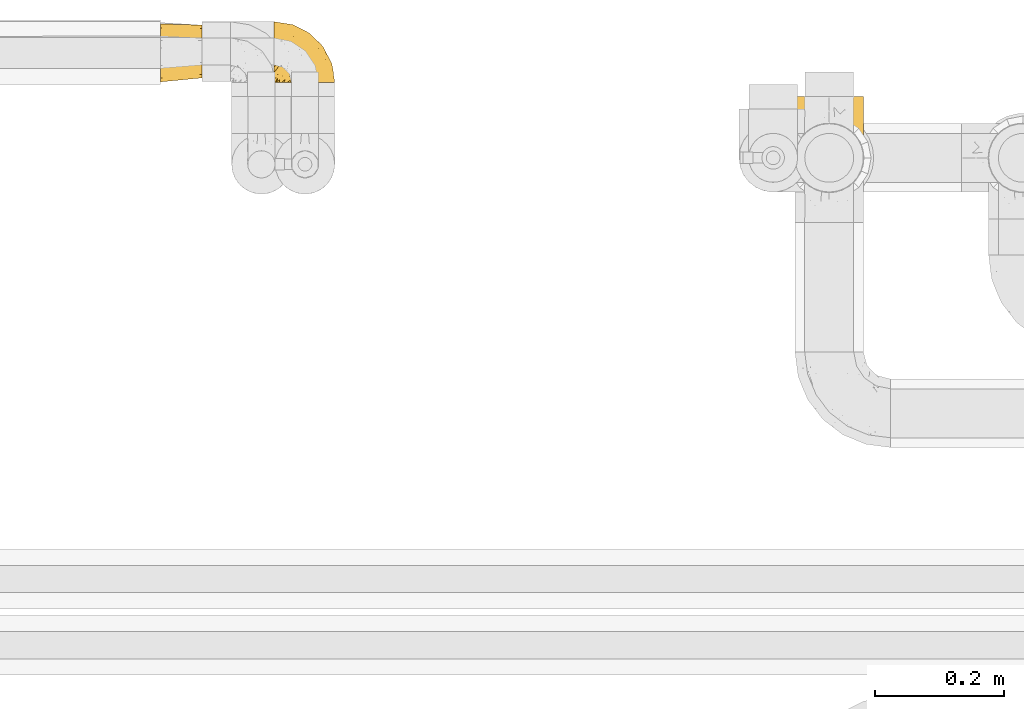
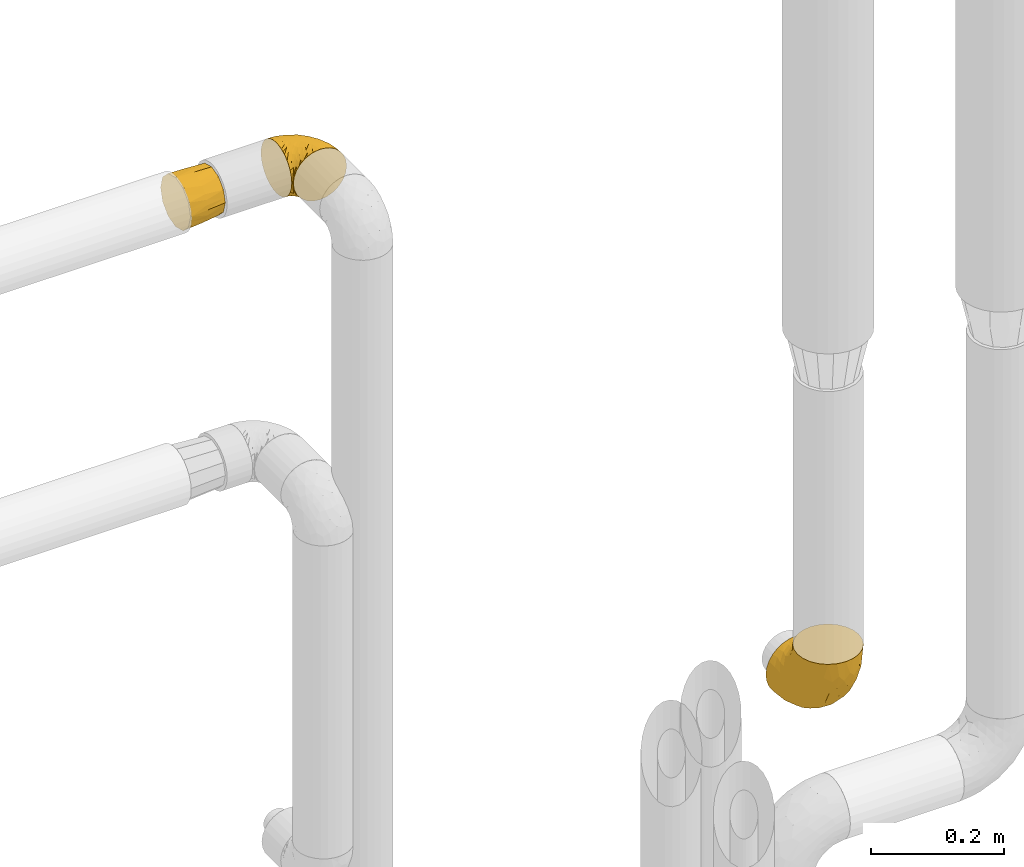
# One storey, part 319 of 827: 3 coverings.
"""IFC2X3 building model written with IfcOpenShell, lengths in millimetres."""

from ifc_helpers import new_model, entity, si_unit, converted_unit, derived_unit, direction, frame, origin, place, context, subcontext, project, spatial, faceted_brep, element, save


model = new_model("IFC2X3")

# Units and contexts
model_context = context("Model", 3, precision=0.01, world=origin(), true_north=direction((6.12303176911189e-17, 1.0)))
body_context = subcontext(model_context, "Body", "Model", "MODEL_VIEW")
ifc_project = project(units=[si_unit("LENGTHUNIT", "METRE", prefix="MILLI"), si_unit("AREAUNIT", "SQUARE_METRE"), si_unit("VOLUMEUNIT", "CUBIC_METRE"), converted_unit("PLANEANGLEUNIT", "DEGREE", entity("IfcRatioMeasure", 0.0174532925199433), si_unit("PLANEANGLEUNIT", "RADIAN"), dimensions=[0, 0, 0, 0, 0, 0, 0]), si_unit("MASSUNIT", "GRAM", prefix="KILO"), derived_unit("MASSDENSITYUNIT", [(si_unit("MASSUNIT", "GRAM", prefix="KILO"), 1), (si_unit("LENGTHUNIT", "METRE"), -3)]), derived_unit("MOMENTOFINERTIAUNIT", [(si_unit("LENGTHUNIT", "METRE"), 4)]), si_unit("TIMEUNIT", "SECOND"), si_unit("FREQUENCYUNIT", "HERTZ"), si_unit("THERMODYNAMICTEMPERATUREUNIT", "DEGREE_CELSIUS"), derived_unit("THERMALTRANSMITTANCEUNIT", [(si_unit("MASSUNIT", "GRAM", prefix="KILO"), 1), (si_unit("THERMODYNAMICTEMPERATUREUNIT", "KELVIN"), -1), (si_unit("TIMEUNIT", "SECOND"), -3)]), derived_unit("VOLUMETRICFLOWRATEUNIT", [(si_unit("LENGTHUNIT", "METRE"), 3), (si_unit("TIMEUNIT", "SECOND"), -1)]), derived_unit("MASSFLOWRATEUNIT", [(si_unit("MASSUNIT", "GRAM", prefix="KILO"), 1), (si_unit("TIMEUNIT", "SECOND"), -1)]), derived_unit("ROTATIONALFREQUENCYUNIT", [(si_unit("TIMEUNIT", "SECOND"), -1)]), si_unit("ELECTRICCURRENTUNIT", "AMPERE"), si_unit("ELECTRICVOLTAGEUNIT", "VOLT"), si_unit("POWERUNIT", "WATT"), si_unit("FORCEUNIT", "NEWTON", prefix="KILO"), si_unit("ILLUMINANCEUNIT", "LUX"), si_unit("LUMINOUSFLUXUNIT", "LUMEN"), si_unit("LUMINOUSINTENSITYUNIT", "CANDELA"), derived_unit("USERDEFINED", [(si_unit("MASSUNIT", "GRAM", prefix="KILO"), -1), (si_unit("LENGTHUNIT", "METRE"), -2), (si_unit("TIMEUNIT", "SECOND"), 3), (si_unit("LUMINOUSFLUXUNIT", "LUMEN"), 1)]), derived_unit("LINEARVELOCITYUNIT", [(si_unit("LENGTHUNIT", "METRE"), 1), (si_unit("TIMEUNIT", "SECOND"), -1)]), si_unit("PRESSUREUNIT", "PASCAL"), derived_unit("USERDEFINED", [(si_unit("LENGTHUNIT", "METRE"), -2), (si_unit("MASSUNIT", "GRAM", prefix="KILO"), 1), (si_unit("TIMEUNIT", "SECOND"), -2)]), derived_unit("LINEARFORCEUNIT", [(si_unit("MASSUNIT", "GRAM", prefix="KILO"), 1), (si_unit("LENGTHUNIT", "METRE"), 1), (si_unit("TIMEUNIT", "SECOND"), -2), (si_unit("LENGTHUNIT", "METRE"), -1)]), derived_unit("PLANARFORCEUNIT", [(si_unit("MASSUNIT", "GRAM", prefix="KILO"), 1), (si_unit("LENGTHUNIT", "METRE"), 1), (si_unit("TIMEUNIT", "SECOND"), -2), (si_unit("LENGTHUNIT", "METRE"), -2)])], contexts=[model_context])

# Site, building, storey
site_placement = place(None, origin())
site = spatial("IfcSite", under=ifc_project, at=site_placement, CompositionType="ELEMENT")
building_placement = place(site_placement, origin())
building = spatial("IfcBuilding", under=site, at=building_placement, CompositionType="ELEMENT")
storey_placement = place(building_placement, frame((0.0, 0.0, 28200.0)))
storey = spatial("IfcBuildingStorey", under=building, at=storey_placement, Name="08", CompositionType="ELEMENT", Elevation=28200.0)

# Coverings
covering_1_placement = place(storey_placement, frame((30592.61, 19468.84, 2252.2)))
element("IfcCovering", 1, at=covering_1_placement, inside=storey, Name=":ADSK_", ObjectType=":ADSK_", PredefinedType="INSULATION", context=body_context, shape_type="Brep", body=[
    faceted_brep([(1.6, 78.41, 83.91), (1.6, 85.72, 76.59), (1.6, 91.22, 67.83), (1.6, 94.64, 58.07), (1.6, 95.8, 47.8), (1.6, 94.64, 37.51), (1.6, 91.22, 27.74), (1.6, 85.71, 18.98), (1.6, 78.39, 11.67), (1.6, 69.63, 6.17), (1.6, 59.87, 2.75), (1.6, 49.6, 1.6), (1.6, 45.45, 2.06), (1.6, 42.38, 2.41), (1.6, 39.31, 2.75), (1.6, 34.43, 4.46), (1.6, 29.54, 6.17), (1.6, 25.16, 8.93), (1.6, 20.78, 11.68), (1.6, 17.13, 15.34), (1.6, 13.47, 19.0), (1.6, 7.97, 27.76), (1.6, 6.26, 32.64), (1.6, 4.55, 37.52), (1.6, 3.4, 47.8), (1.6, 4.55, 58.08), (1.6, 6.26, 62.96), (1.6, 7.97, 67.85), (1.6, 13.48, 76.61), (1.6, 17.14, 80.26), (1.6, 20.8, 83.92), (1.6, 25.18, 86.67), (1.6, 29.56, 89.42), (1.6, 34.44, 91.13), (1.6, 39.32, 92.84), (1.6, 42.39, 93.18), (1.6, 45.45, 93.53), (1.6, 49.6, 94.0), (1.6, 59.88, 92.84), (1.6, 69.65, 89.42), (3.4, 1.6, 47.8), (4.97, 1.6, 35.84), (9.58, 1.6, 24.7), (13.26, 1.6, 19.91), (16.93, 1.6, 15.13), (21.71, 1.6, 11.46), (26.5, 1.6, 7.78), (32.07, 1.6, 5.48), (37.64, 1.6, 3.17), (41.25, 1.6, 2.69), (43.34, 1.6, 2.42), (45.42, 1.6, 2.14), (49.6, 1.6, 1.6), (61.55, 1.6, 3.17), (72.7, 1.6, 7.78), (82.26, 1.6, 15.13), (89.61, 1.6, 24.7), (94.22, 1.6, 35.84), (95.8, 1.6, 47.8), (94.22, 1.6, 59.75), (89.61, 1.6, 70.9), (82.26, 1.6, 80.46), (72.7, 1.6, 87.81), (61.55, 1.6, 92.42), (49.6, 1.6, 94.0), (45.42, 1.6, 93.45), (41.25, 1.6, 92.9), (37.64, 1.6, 92.42), (32.07, 1.6, 90.11), (26.5, 1.6, 87.81), (21.71, 1.6, 84.13), (16.93, 1.6, 80.46), (13.26, 1.6, 75.68), (9.58, 1.6, 70.9), (4.97, 1.6, 59.75), (81.55, 36.81, 71.98), (90.4, 23.28, 63.6), (83.0, 45.8, 59.72), (91.18, 30.7, 47.8), (93.13, 21.2, 55.16), (94.0, 12.96, 47.8), (66.19, 66.19, 63.76), (70.92, 54.51, 72.22), (85.95, 17.98, 74.18), (49.74, 36.69, 92.52), (35.54, 35.54, 94.0), (38.14, 31.64, 94.0), (40.74, 27.75, 94.0), (43.34, 23.86, 94.0), (45.94, 19.96, 94.0), (77.59, 22.8, 82.14), (71.17, 42.67, 80.34), (65.81, 33.21, 87.52), (59.03, 59.45, 79.59), (45.85, 71.5, 78.25), (45.79, 62.66, 85.01), (41.42, 54.5, 90.25), (34.51, 47.57, 93.2), (56.04, 48.81, 87.23), (15.15, 74.98, 85.55), (56.51, 18.7, 93.0), (68.39, 15.75, 89.31), (23.33, 91.17, 61.31), (42.86, 85.28, 56.86), (39.42, 82.58, 68.34), (53.58, 75.78, 65.71), (59.17, 74.98, 56.99), (59.06, 67.27, 72.15), (22.63, 87.38, 70.34), (20.55, 82.04, 78.36), (12.96, 94.0, 47.8), (56.96, 77.8, 47.8), (67.38, 67.38, 47.8), (18.72, 56.2, 93.06), (5.33, 48.85, 94.0), (9.07, 48.11, 94.0), (11.79, 47.57, 94.0), (14.51, 47.03, 94.0), (17.24, 46.48, 94.0), (19.96, 45.94, 94.0), (21.03, 65.78, 89.88), (46.48, 17.24, 94.0), (47.03, 14.51, 94.0), (47.57, 11.79, 94.0), (48.11, 9.07, 94.0), (48.48, 7.2, 94.0), (48.85, 5.33, 94.0), (30.7, 91.18, 47.8), (23.86, 43.34, 94.0), (27.75, 40.74, 94.0), (31.64, 38.14, 94.0), (31.26, 72.73, 83.7), (77.8, 56.96, 47.8), (72.75, 62.23, 55.9), (43.83, 84.49, 47.8), (84.49, 43.83, 47.8), (14.58, 12.05, 81.75), (16.17, 18.95, 86.43), (10.82, 13.02, 79.8), (4.64, 8.34, 69.84), (7.71, 14.63, 79.5), (25.13, 11.09, 88.08), (32.66, 13.66, 91.6), (34.94, 20.08, 92.93), (36.76, 9.61, 92.43), (40.48, 9.48, 93.24), (39.25, 16.1, 93.36), (3.69, 3.42, 57.25), (13.99, 26.63, 89.41), (21.85, 33.72, 92.89), (17.93, 34.77, 92.66), (15.11, 6.75, 79.58), (21.14, 13.31, 86.51), (7.21, 19.94, 83.91), (9.47, 27.05, 88.76), (32.27, 8.67, 90.94), (25.68, 26.11, 91.94), (22.18, 29.3, 91.98), (18.79, 6.32, 82.79), (10.12, 39.92, 93.16), (10.45, 6.04, 73.94), (11.29, 34.4, 91.89), (2.87, 2.87, 47.8), (31.16, 20.92, 92.22), (12.7, 21.11, 86.29), (6.31, 27.43, 88.56), (25.62, 7.54, 87.72), (21.18, 18.45, 88.33), (28.81, 23.88, 92.18), (7.45, 7.77, 71.78), (21.14, 13.3, 9.09), (25.13, 11.09, 7.51), (18.79, 6.33, 12.8), (48.11, 9.07, 1.6), (48.85, 5.33, 1.6), (47.03, 14.51, 1.6), (47.57, 11.79, 1.6), (3.69, 3.42, 38.35), (7.44, 7.76, 23.84), (14.51, 47.03, 1.6), (11.79, 47.57, 1.6), (5.33, 48.85, 1.6), (9.07, 48.11, 1.6), (7.71, 14.62, 16.1), (9.47, 27.03, 6.84), (34.94, 20.08, 2.66), (31.16, 20.92, 3.37), (40.74, 27.75, 1.6), (38.14, 31.64, 1.6), (36.76, 9.61, 3.16), (40.48, 9.48, 2.35), (4.63, 8.33, 25.77), (15.11, 6.74, 16.02), (14.58, 12.04, 13.85), (43.34, 23.86, 1.6), (45.94, 19.96, 1.6), (39.25, 16.1, 2.23), (7.21, 19.93, 11.69), (12.69, 21.1, 9.31), (10.14, 39.92, 2.43), (21.81, 33.68, 2.71), (22.19, 29.28, 3.61), (14.0, 26.62, 6.18), (25.69, 26.08, 3.66), (16.17, 18.93, 9.17), (6.66, 27.87, 6.77), (17.92, 34.75, 2.93), (10.45, 6.04, 21.66), (31.64, 38.14, 1.6), (10.64, 12.79, 16.09), (11.31, 34.41, 3.7), (19.96, 45.94, 1.6), (23.86, 43.34, 1.6), (27.75, 40.74, 1.6), (32.66, 13.66, 3.99), (46.48, 17.24, 1.6), (32.27, 8.67, 4.65), (35.54, 35.54, 1.6), (28.77, 23.83, 3.43), (21.17, 18.43, 7.27), (23.36, 6.03, 9.46), (17.24, 46.48, 1.6), (47.58, 34.52, 2.4), (93.13, 21.2, 40.43), (77.44, 23.82, 13.57), (66.78, 41.32, 11.3), (71.68, 47.62, 18.65), (74.96, 52.66, 27.26), (81.55, 36.81, 23.61), (36.7, 49.75, 3.07), (56.9, 19.07, 2.69), (83.0, 45.8, 35.87), (90.4, 23.28, 31.99), (67.83, 21.35, 6.71), (85.95, 17.98, 21.41), (39.41, 82.57, 27.24), (23.33, 91.17, 34.26), (42.87, 85.27, 38.73), (53.92, 73.89, 26.97), (66.19, 66.19, 31.83), (64.12, 62.43, 23.4), (33.13, 63.53, 6.91), (23.1, 58.45, 3.4), (16.98, 67.16, 5.84), (72.75, 62.22, 39.69), (23.77, 81.54, 17.6), (18.41, 74.8, 10.38), (43.7, 75.83, 20.6), (54.53, 41.45, 5.36), (55.72, 76.72, 35.73), (17.73, 88.2, 24.84), (38.98, 71.6, 13.87), (50.28, 56.23, 9.06), (59.02, 59.44, 15.99)], [[[0, 1, 2, 3, 4, 5, 6, 7, 8, 9, 10, 11, 12, 13, 14, 15, 16, 17, 18, 19, 20, 21, 22, 23, 24, 25, 26, 27, 28, 29, 30, 31, 32, 33, 34, 35, 36, 37, 38, 39]], [[40, 41, 42, 43, 44, 45, 46, 47, 48, 49, 50, 51, 52, 53, 54, 55, 56, 57, 58, 59, 60, 61, 62, 63, 64, 65, 66, 67, 68, 69, 70, 71, 72, 73, 74]], [[75, 76, 77]], [[78, 79, 80]], [[77, 81, 82]], [[76, 75, 83]], [[84, 85, 86, 87, 88, 89]], [[90, 91, 92]], [[76, 60, 59]], [[93, 94, 95]], [[90, 62, 61]], [[83, 61, 60]], [[96, 97, 84]], [[98, 93, 95]], [[0, 39, 99]], [[100, 84, 89]], [[62, 101, 63]], [[2, 102, 3]], [[92, 84, 100]], [[103, 102, 104]], [[103, 105, 106]], [[93, 107, 94]], [[1, 108, 2]], [[92, 101, 90]], [[108, 1, 109]], [[102, 110, 3]], [[93, 82, 107]], [[102, 108, 104]], [[111, 106, 112]], [[109, 0, 99]], [[113, 37, 114, 115, 116, 117, 118, 119]], [[120, 38, 113]], [[100, 89, 121, 122, 123, 124, 125, 126, 64]], [[127, 102, 103]], [[97, 119, 128, 129, 130, 85]], [[99, 120, 131]], [[132, 133, 77]], [[59, 80, 79]], [[1, 0, 109]], [[98, 84, 92]], [[94, 109, 131]], [[120, 39, 38]], [[93, 91, 82]], [[104, 94, 105]], [[97, 113, 119]], [[95, 120, 96]], [[83, 90, 61]], [[91, 93, 98]], [[64, 63, 100]], [[100, 63, 101]], [[77, 76, 79]], [[133, 106, 81]], [[84, 97, 85]], [[113, 96, 120]], [[113, 97, 96]], [[37, 113, 38]], [[110, 102, 127]], [[110, 4, 3]], [[103, 111, 134, 127]], [[90, 75, 91]], [[82, 81, 107]], [[91, 75, 82]], [[77, 82, 75]], [[76, 83, 60]], [[90, 83, 75]], [[105, 107, 81]], [[94, 131, 95]], [[105, 94, 107]], [[109, 94, 104]], [[120, 95, 131]], [[98, 95, 96]], [[84, 98, 96]], [[98, 92, 91]], [[106, 105, 81]], [[103, 104, 105]], [[133, 132, 112]], [[103, 106, 111]], [[77, 78, 135, 132]], [[106, 133, 112]], [[77, 133, 81]], [[120, 99, 39]], [[109, 99, 131]], [[59, 58, 80]], [[59, 79, 76]], [[90, 101, 62]], [[100, 101, 92]], [[2, 108, 102]], [[109, 104, 108]], [[78, 77, 79]], [[136, 137, 138]], [[27, 139, 140]], [[141, 142, 143]], [[144, 145, 121]], [[146, 89, 88]], [[147, 139, 25]], [[148, 149, 150]], [[136, 151, 152]], [[147, 40, 74]], [[24, 147, 25]], [[153, 148, 154]], [[33, 116, 34]], [[73, 72, 151]], [[114, 37, 36, 35, 34, 116, 115]], [[146, 155, 144]], [[156, 85, 130]], [[157, 149, 148]], [[151, 158, 152]], [[117, 33, 159]], [[29, 153, 154]], [[160, 74, 73]], [[161, 128, 119]], [[65, 64, 126, 125, 124, 123, 122, 67, 66]], [[162, 147, 24]], [[27, 140, 28]], [[149, 129, 150]], [[139, 27, 26, 25]], [[68, 144, 69]], [[129, 128, 150]], [[163, 87, 86]], [[130, 129, 149]], [[122, 145, 67]], [[153, 164, 148]], [[161, 119, 159]], [[165, 30, 154]], [[150, 154, 148]], [[128, 161, 150]], [[30, 165, 31]], [[145, 144, 68]], [[89, 146, 144]], [[87, 163, 143]], [[166, 155, 142]], [[88, 87, 143]], [[161, 154, 150]], [[154, 30, 29]], [[29, 28, 153]], [[28, 140, 153]], [[164, 153, 140]], [[140, 137, 164]], [[157, 148, 164]], [[156, 130, 157]], [[164, 137, 157]], [[157, 137, 156]], [[167, 137, 136]], [[168, 85, 156]], [[152, 168, 167]], [[167, 168, 156]], [[163, 152, 141]], [[71, 158, 72]], [[152, 167, 136]], [[88, 142, 146]], [[144, 155, 69]], [[146, 142, 155]], [[70, 166, 71]], [[142, 141, 166]], [[70, 69, 155]], [[141, 158, 71]], [[160, 73, 151]], [[138, 137, 140]], [[160, 136, 169]], [[136, 160, 151]], [[74, 160, 169]], [[152, 158, 141]], [[151, 72, 158]], [[168, 152, 163]], [[137, 167, 156]], [[163, 86, 168]], [[85, 168, 86]], [[116, 33, 117]], [[130, 149, 157]], [[67, 145, 68]], [[121, 89, 144]], [[145, 122, 121]], [[40, 147, 162]], [[169, 147, 74]], [[159, 33, 32]], [[161, 159, 32]], [[159, 119, 118, 117]], [[139, 147, 169]], [[139, 169, 138]], [[161, 32, 31]], [[141, 143, 163]], [[88, 143, 142]], [[71, 166, 141]], [[155, 166, 70]], [[139, 138, 140]], [[169, 136, 138]], [[154, 161, 165]], [[161, 31, 165]], [[170, 171, 172]], [[173, 174, 52, 51, 50, 49, 48, 175, 176]], [[177, 178, 41]], [[179, 15, 180]], [[12, 11, 181, 182, 180, 14, 13]], [[183, 21, 20]], [[19, 18, 184]], [[185, 186, 187]], [[186, 188, 187]], [[43, 172, 44]], [[189, 190, 47]], [[23, 22, 21, 191]], [[170, 192, 193]], [[40, 162, 177]], [[194, 195, 196]], [[24, 23, 177]], [[197, 198, 183]], [[199, 15, 179]], [[47, 46, 189]], [[200, 201, 202]], [[201, 203, 204]], [[205, 206, 184]], [[207, 41, 178]], [[16, 15, 199]], [[14, 180, 15]], [[202, 201, 198]], [[208, 201, 200]], [[162, 24, 177]], [[48, 47, 190]], [[196, 195, 189]], [[197, 184, 202]], [[204, 193, 209]], [[210, 211, 212]], [[206, 212, 213]], [[205, 17, 210]], [[184, 206, 202]], [[210, 212, 206]], [[185, 194, 214]], [[189, 215, 190]], [[216, 45, 214]], [[186, 171, 170]], [[189, 216, 196]], [[197, 20, 19]], [[194, 185, 187]], [[197, 183, 20]], [[184, 197, 19]], [[197, 202, 198]], [[206, 200, 202]], [[204, 183, 198]], [[201, 208, 203]], [[203, 208, 217]], [[204, 198, 201]], [[217, 188, 218]], [[193, 219, 170]], [[171, 186, 185]], [[170, 218, 186]], [[170, 219, 218]], [[42, 207, 192]], [[171, 220, 172]], [[216, 189, 46]], [[214, 194, 196]], [[44, 220, 45]], [[214, 196, 216]], [[216, 46, 45]], [[214, 45, 220]], [[192, 43, 42]], [[204, 203, 219]], [[207, 193, 192]], [[209, 193, 178]], [[41, 207, 42]], [[193, 207, 178]], [[43, 192, 172]], [[170, 172, 192]], [[204, 219, 193]], [[219, 203, 218]], [[217, 218, 203]], [[188, 186, 218]], [[206, 213, 200]], [[208, 200, 213]], [[199, 210, 16]], [[215, 189, 195]], [[215, 175, 190]], [[175, 48, 190]], [[199, 179, 221, 211]], [[210, 199, 211]], [[23, 191, 177]], [[40, 177, 41]], [[183, 209, 191]], [[183, 191, 21]], [[191, 178, 177]], [[205, 18, 17]], [[17, 16, 210]], [[171, 185, 214]], [[172, 220, 44]], [[214, 220, 171]], [[191, 209, 178]], [[204, 209, 183]], [[206, 205, 210]], [[18, 205, 184]], [[222, 195, 194, 187, 188, 217]], [[57, 223, 80]], [[224, 225, 226]], [[226, 227, 228]], [[229, 217, 208, 213, 212, 211]], [[230, 52, 174, 173, 176, 175, 215, 195]], [[231, 232, 228]], [[231, 78, 223]], [[223, 57, 232]], [[224, 233, 225]], [[233, 54, 53]], [[234, 232, 56]], [[56, 55, 234]], [[234, 224, 228]], [[235, 236, 237]], [[224, 55, 54]], [[238, 239, 240]], [[52, 230, 53]], [[241, 242, 243]], [[231, 227, 244]], [[11, 10, 242]], [[236, 6, 5]], [[7, 245, 8]], [[8, 246, 9]], [[238, 247, 235]], [[222, 229, 248]], [[242, 211, 221, 179, 180, 182, 181, 11]], [[233, 53, 230]], [[111, 112, 249]], [[250, 6, 236]], [[246, 251, 241]], [[6, 250, 7]], [[127, 236, 110]], [[248, 229, 252]], [[246, 8, 245]], [[235, 245, 250]], [[236, 5, 110]], [[235, 249, 238]], [[237, 236, 127]], [[243, 9, 246]], [[252, 229, 241]], [[56, 232, 57]], [[222, 230, 195]], [[225, 248, 252]], [[248, 233, 230]], [[54, 233, 224]], [[231, 228, 227]], [[244, 132, 231]], [[248, 225, 233]], [[226, 225, 253]], [[235, 250, 236]], [[245, 7, 250]], [[251, 246, 245]], [[243, 246, 241]], [[247, 245, 235]], [[252, 251, 253]], [[229, 222, 217]], [[230, 222, 248]], [[5, 4, 110]], [[237, 127, 134, 111]], [[238, 249, 239]], [[224, 234, 55]], [[232, 234, 228]], [[242, 241, 229]], [[10, 9, 243]], [[211, 242, 229]], [[10, 243, 242]], [[80, 223, 78]], [[80, 58, 57]], [[231, 223, 232]], [[227, 240, 239]], [[224, 226, 228]], [[240, 226, 253]], [[227, 239, 244]], [[226, 240, 227]], [[251, 247, 253]], [[240, 253, 247]], [[249, 235, 237]], [[237, 111, 249]], [[244, 239, 249]], [[112, 244, 249]], [[135, 78, 231, 132]], [[112, 132, 244]], [[247, 238, 240]], [[245, 247, 251]], [[251, 252, 241]], [[225, 252, 253]]]),
])
covering_2_placement = place(storey_placement, frame((30418.2, 19469.61, 2253.4)))
element("IfcCovering", 2, at=covering_2_placement, inside=storey, Name=":ADSK_", ObjectType=":ADSK_", PredefinedType="INSULATION", context=body_context, shape_type="Brep", body=[
    faceted_brep([(0.0, 77.33, 77.33), (0.0, 85.57, 69.1), (0.0, 88.58, 57.85), (0.0, 91.6, 46.6), (0.0, 88.58, 35.35), (0.0, 85.57, 24.1), (0.0, 77.33, 15.86), (0.0, 69.1, 7.62), (0.0, 57.85, 4.61), (0.0, 46.6, 1.6), (0.0, 35.35, 4.61), (0.0, 24.1, 7.62), (0.0, 15.86, 15.86), (0.0, 7.62, 24.1), (0.0, 4.61, 35.35), (0.0, 1.6, 46.6), (0.0, 4.61, 57.85), (0.0, 7.62, 69.1), (0.0, 15.86, 77.33), (0.0, 24.1, 85.57), (0.0, 35.35, 88.58), (0.0, 46.6, 91.6), (0.0, 57.85, 88.58), (0.0, 69.1, 85.57), (64.0, 28.33, 82.1), (64.0, 20.82, 74.6), (64.0, 13.32, 67.1), (64.0, 9.91, 54.38), (64.0, 7.83, 46.6), (64.0, 10.57, 36.35), (64.0, 13.32, 26.1), (64.0, 20.82, 18.59), (64.0, 28.33, 11.09), (64.0, 41.04, 7.68), (64.0, 48.83, 5.6), (64.0, 59.08, 8.34), (64.0, 69.33, 11.09), (64.0, 76.83, 18.59), (64.0, 84.33, 26.1), (64.0, 87.74, 38.8), (64.0, 89.83, 46.6), (64.0, 87.08, 56.85), (64.0, 84.33, 67.1), (64.0, 76.83, 74.6), (64.0, 69.33, 82.1), (64.0, 56.62, 85.51), (64.0, 48.83, 87.6), (64.0, 38.58, 84.85), (32.0, 87.44, 30.14), (30.57, 89.92, 38.19), (31.14, 90.73, 46.6), (32.0, 83.16, 22.25), (32.0, 58.4, 4.94), (32.0, 73.89, 12.48), (32.0, 66.24, 7.79), (31.14, 47.68, 3.54), (32.0, 31.26, 6.87), (30.57, 39.25, 4.33), (32.0, 23.37, 11.15), (32.0, 6.06, 35.91), (32.0, 13.6, 20.42), (32.0, 8.91, 28.07), (31.19, 4.63, 46.6), (32.0, 7.98, 63.05), (30.57, 5.4, 55.0), (32.0, 12.26, 70.94), (32.0, 37.02, 88.25), (32.0, 21.53, 80.71), (32.0, 29.19, 85.4), (31.19, 47.68, 89.65), (32.0, 64.17, 86.32), (30.57, 56.07, 88.86), (32.0, 72.05, 82.04), (32.0, 89.36, 57.28), (32.0, 81.82, 72.77), (32.0, 86.52, 65.12)], [[[0, 1, 2, 3, 4, 5, 6, 7, 8, 9, 10, 11, 12, 13, 14, 15, 16, 17, 18, 19, 20, 21, 22, 23]], [[24, 25, 26, 27, 28, 29, 30, 31, 32, 33, 34, 35, 36, 37, 38, 39, 40, 41, 42, 43, 44, 45, 46, 47]], [[39, 48, 49]], [[39, 50, 40]], [[48, 39, 38]], [[5, 4, 48]], [[51, 5, 48]], [[48, 4, 49]], [[9, 8, 52]], [[53, 51, 37]], [[51, 48, 38]], [[7, 53, 54]], [[54, 53, 36]], [[37, 36, 53]], [[51, 38, 37]], [[50, 49, 3]], [[53, 6, 51]], [[6, 5, 51]], [[6, 53, 7]], [[52, 8, 54]], [[54, 35, 52]], [[54, 36, 35]], [[3, 49, 4]], [[8, 7, 54]], [[34, 55, 9, 52]], [[39, 49, 50]], [[34, 52, 35]], [[33, 56, 57]], [[33, 55, 34]], [[56, 33, 32]], [[11, 10, 56]], [[58, 11, 56]], [[56, 10, 57]], [[15, 14, 59]], [[60, 58, 31]], [[58, 56, 32]], [[13, 60, 61]], [[61, 60, 30]], [[31, 30, 60]], [[58, 32, 31]], [[55, 57, 9]], [[60, 12, 58]], [[12, 11, 58]], [[12, 60, 13]], [[59, 14, 61]], [[61, 29, 59]], [[61, 30, 29]], [[9, 57, 10]], [[14, 13, 61]], [[28, 62, 15, 59]], [[33, 57, 55]], [[28, 59, 29]], [[27, 63, 64]], [[27, 62, 28]], [[63, 27, 26]], [[17, 16, 63]], [[65, 17, 63]], [[63, 16, 64]], [[21, 20, 66]], [[67, 65, 25]], [[65, 63, 26]], [[19, 67, 68]], [[68, 67, 24]], [[25, 24, 67]], [[65, 26, 25]], [[62, 64, 15]], [[67, 18, 65]], [[18, 17, 65]], [[18, 67, 19]], [[66, 20, 68]], [[68, 47, 66]], [[68, 24, 47]], [[15, 64, 16]], [[20, 19, 68]], [[46, 69, 21, 66]], [[27, 64, 62]], [[46, 66, 47]], [[45, 70, 71]], [[45, 69, 46]], [[70, 45, 44]], [[23, 22, 70]], [[72, 23, 70]], [[70, 22, 71]], [[3, 2, 73]], [[74, 72, 43]], [[72, 70, 44]], [[1, 74, 75]], [[75, 74, 42]], [[43, 42, 74]], [[72, 44, 43]], [[69, 71, 21]], [[74, 0, 72]], [[0, 23, 72]], [[0, 74, 1]], [[73, 2, 75]], [[75, 41, 73]], [[75, 42, 41]], [[21, 71, 22]], [[2, 1, 75]], [[40, 50, 3, 73]], [[45, 71, 69]], [[40, 73, 41]]]),
])
covering_3_placement = place(storey_placement, frame((31400.76, 19298.79, 1075.8)))
element("IfcCovering", 3, at=covering_3_placement, inside=storey, Name=":ADSK_", ObjectType=":ADSK_", PredefinedType="INSULATION", context=body_context, shape_type="Brep", body=[
    faceted_brep([(66.44, 149.65, 2.92), (54.65, 149.65, 1.6), (42.84, 149.65, 2.93), (31.62, 149.65, 6.85), (21.56, 149.65, 13.18), (13.16, 149.65, 21.58), (6.84, 149.65, 31.64), (2.92, 149.65, 42.85), (1.6, 149.65, 54.65), (2.93, 149.65, 66.46), (6.85, 149.65, 77.67), (13.18, 149.65, 87.73), (21.58, 149.65, 96.13), (31.64, 149.65, 102.45), (42.85, 149.65, 106.37), (54.65, 149.65, 107.7), (66.46, 149.65, 106.36), (77.67, 149.65, 102.44), (87.73, 149.65, 96.11), (96.13, 149.65, 87.71), (102.45, 149.65, 77.65), (106.37, 149.65, 66.44), (107.7, 149.65, 54.65), (106.36, 149.65, 42.84), (102.44, 149.65, 31.62), (96.11, 149.65, 21.56), (87.71, 149.65, 13.16), (77.65, 149.65, 6.84), (40.91, 105.89, 149.65), (28.12, 100.59, 149.65), (17.13, 92.16, 149.65), (8.7, 81.17, 149.65), (3.4, 68.38, 149.65), (1.6, 54.65, 149.65), (3.4, 40.91, 149.65), (8.7, 28.12, 149.65), (17.13, 17.13, 149.65), (28.12, 8.7, 149.65), (40.91, 3.4, 149.65), (54.65, 1.6, 149.65), (68.38, 3.4, 149.65), (81.17, 8.7, 149.65), (92.16, 17.13, 149.65), (100.59, 28.12, 149.65), (105.89, 40.91, 149.65), (107.7, 54.65, 149.65), (105.89, 68.38, 149.65), (100.59, 81.17, 149.65), (92.16, 92.16, 149.65), (81.17, 100.59, 149.65), (68.38, 105.89, 149.65), (54.65, 107.7, 149.65), (85.53, 14.05, 123.27), (73.42, 9.45, 114.15), (83.77, 22.36, 92.97), (64.22, 4.7, 124.11), (54.65, 6.64, 111.33), (96.72, 81.47, 42.13), (93.36, 56.83, 56.83), (84.47, 64.02, 40.31), (71.37, 34.04, 61.55), (54.65, 21.43, 75.62), (54.65, 44.96, 44.96), (103.47, 49.8, 91.12), (100.91, 35.43, 109.83), (99.1, 42.1, 88.02), (105.43, 43.59, 119.19), (106.79, 57.88, 99.11), (89.81, 91.8, 27.97), (79.59, 88.01, 21.92), (81.29, 115.65, 12.94), (74.01, 18.94, 88.29), (64.14, 12.83, 95.35), (94.75, 24.96, 113.84), (54.65, 111.33, 6.64), (70.74, 113.8, 8.58), (68.3, 60.89, 33.39), (66.05, 86.24, 17.23), (100.73, 65.84, 61.99), (106.78, 124.58, 47.9), (103.6, 121.36, 37.72), (107.7, 72.79, 93.81), (107.7, 66.04, 107.05), (107.7, 59.29, 120.29), (106.07, 73.26, 73.26), (90.59, 121.69, 18.58), (97.43, 109.82, 29.72), (84.51, 40.11, 64.31), (93.3, 36.57, 82.84), (107.7, 93.81, 72.79), (107.7, 83.3, 83.3), (107.7, 136.6, 56.71), (107.7, 120.29, 59.29), (106.79, 99.11, 57.88), (107.7, 107.05, 66.04), (103.47, 91.12, 49.8), (54.65, 75.62, 21.43), (107.7, 56.97, 134.97), (76.99, 126.65, 108.79), (84.28, 116.55, 110.84), (91.11, 120.09, 101.53), (106.26, 76.06, 111.84), (102.6, 83.69, 119.98), (106.08, 71.88, 123.54), (106.56, 66.92, 134.54), (105.36, 110.43, 80.57), (106.74, 121.31, 69.55), (101.59, 81.0, 134.56), (54.65, 113.32, 128.67), (54.65, 111.09, 136.98), (67.71, 109.14, 133.56), (91.36, 95.86, 131.66), (94.33, 99.07, 117.75), (87.1, 106.92, 118.23), (65.84, 131.39, 110.55), (54.65, 136.98, 111.09), (54.65, 128.67, 113.32), (68.92, 117.07, 120.2), (100.82, 96.39, 105.95), (79.83, 106.61, 127.69), (77.13, 103.72, 139.88), (105.9, 92.14, 92.14), (101.53, 107.13, 93.82), (106.72, 98.03, 82.28), (97.75, 88.38, 130.86), (103.08, 130.66, 78.78), (106.39, 135.45, 67.58), (98.1, 123.57, 90.58), (95.02, 137.75, 90.23), (86.9, 133.2, 99.39), (74.42, 138.8, 105.17), (54.65, 120.99, 120.99), (105.28, 84.53, 104.59), (92.87, 108.72, 108.24), (17.93, 95.86, 131.66), (6.22, 130.67, 78.8), (41.58, 109.13, 133.57), (1.6, 93.81, 72.79), (2.57, 98.02, 82.27), (3.94, 110.43, 80.59), (43.46, 131.4, 110.55), (32.32, 126.66, 108.79), (40.38, 117.08, 120.2), (16.44, 108.74, 108.25), (8.47, 96.31, 106.06), (15.01, 99.11, 117.78), (11.21, 123.58, 90.6), (7.78, 107.12, 93.87), (1.6, 72.79, 93.81), (1.6, 66.04, 107.05), (3.04, 76.07, 111.89), (1.6, 56.97, 134.97), (2.73, 66.92, 134.54), (1.6, 120.29, 59.29), (1.6, 107.05, 66.04), (2.55, 121.26, 69.56), (3.98, 84.46, 104.56), (6.69, 83.69, 119.98), (7.7, 81.0, 134.56), (3.21, 71.88, 123.54), (14.28, 137.76, 90.25), (22.42, 133.21, 99.4), (25.02, 116.58, 110.83), (18.18, 120.1, 101.52), (34.89, 138.81, 105.18), (1.6, 136.6, 56.71), (32.17, 103.72, 139.89), (22.23, 106.96, 118.22), (2.91, 135.44, 67.6), (11.54, 88.38, 130.86), (1.6, 83.3, 83.3), (3.38, 92.12, 92.12), (29.46, 106.6, 127.71), (1.6, 59.29, 120.29), (25.52, 22.36, 92.97), (23.76, 14.05, 123.27), (14.54, 24.96, 113.84), (8.38, 35.43, 109.83), (45.07, 4.71, 124.03), (35.87, 9.45, 114.15), (45.14, 11.79, 98.04), (2.5, 57.88, 99.11), (2.51, 124.57, 47.9), (5.68, 121.37, 37.74), (5.82, 91.12, 49.8), (15.93, 56.83, 56.83), (12.54, 81.48, 42.16), (24.81, 64.05, 40.3), (2.5, 99.11, 57.88), (3.22, 73.26, 73.26), (3.86, 43.59, 119.19), (35.85, 19.5, 86.61), (19.47, 91.8, 27.99), (18.68, 121.7, 18.59), (29.68, 88.04, 21.92), (27.95, 123.34, 11.28), (40.99, 60.89, 33.39), (37.92, 34.04, 61.55), (11.85, 109.85, 29.73), (10.19, 42.1, 88.01), (8.55, 65.78, 62.08), (38.53, 113.81, 8.58), (15.99, 36.57, 82.84), (24.79, 40.12, 64.3), (5.82, 49.8, 91.12), (40.56, 86.08, 18.05)], [[[0, 1, 2, 3, 4, 5, 6, 7, 8, 9, 10, 11, 12, 13, 14, 15, 16, 17, 18, 19, 20, 21, 22, 23, 24, 25, 26, 27]], [[28, 29, 30, 31, 32, 33, 34, 35, 36, 37, 38, 39, 40, 41, 42, 43, 44, 45, 46, 47, 48, 49, 50, 51]], [[52, 53, 54]], [[55, 39, 56]], [[57, 58, 59]], [[60, 61, 62]], [[63, 64, 65]], [[66, 63, 67]], [[68, 69, 70]], [[53, 71, 54]], [[41, 40, 53]], [[53, 72, 71]], [[73, 42, 52]], [[42, 41, 52]], [[74, 0, 75]], [[69, 76, 77]], [[43, 73, 64]], [[45, 44, 66]], [[57, 78, 58]], [[23, 79, 80]], [[67, 81, 82, 83]], [[67, 84, 81]], [[24, 23, 80]], [[25, 85, 26]], [[86, 85, 25]], [[42, 73, 43]], [[0, 27, 75]], [[25, 24, 86]], [[70, 26, 85]], [[0, 74, 1]], [[68, 85, 86]], [[66, 64, 63]], [[60, 59, 87]], [[54, 87, 88]], [[76, 60, 62]], [[84, 89, 90, 81]], [[79, 22, 91, 92]], [[77, 74, 75]], [[93, 92, 94, 89]], [[80, 86, 24]], [[40, 55, 53]], [[76, 59, 60]], [[93, 84, 95]], [[76, 62, 96]], [[55, 72, 53]], [[70, 27, 26]], [[75, 70, 69]], [[78, 84, 63]], [[93, 79, 92]], [[95, 86, 80]], [[77, 76, 96]], [[59, 69, 68]], [[57, 68, 86]], [[68, 57, 59]], [[59, 58, 87]], [[76, 69, 59]], [[88, 87, 58]], [[87, 54, 71]], [[86, 95, 57]], [[78, 57, 95]], [[84, 78, 95]], [[78, 63, 65]], [[58, 78, 65]], [[54, 88, 73]], [[84, 93, 89]], [[79, 95, 80]], [[79, 93, 95]], [[22, 79, 23]], [[66, 83, 97, 45]], [[84, 67, 63]], [[83, 66, 67]], [[64, 44, 43]], [[64, 66, 44]], [[65, 73, 88]], [[53, 52, 41]], [[73, 52, 54]], [[73, 65, 64]], [[65, 88, 58]], [[39, 55, 40]], [[72, 55, 56]], [[56, 61, 72]], [[60, 72, 61]], [[72, 60, 71]], [[87, 71, 60]], [[27, 70, 75]], [[68, 70, 85]], [[74, 77, 96]], [[69, 77, 75]], [[98, 99, 100]], [[46, 45, 97]], [[101, 102, 103]], [[103, 104, 83]], [[105, 94, 106]], [[107, 103, 102]], [[108, 109, 51, 110]], [[111, 112, 113]], [[114, 115, 116]], [[47, 104, 107]], [[110, 117, 108]], [[49, 48, 111]], [[102, 118, 112]], [[119, 120, 111]], [[50, 49, 120]], [[121, 122, 118]], [[105, 123, 89]], [[124, 48, 107]], [[20, 19, 125]], [[121, 81, 90]], [[117, 119, 99]], [[21, 20, 126]], [[22, 21, 91]], [[105, 125, 127]], [[110, 51, 50]], [[19, 128, 125]], [[16, 15, 115]], [[129, 98, 100]], [[126, 91, 21]], [[128, 129, 127]], [[122, 123, 105]], [[114, 117, 98]], [[17, 16, 130]], [[18, 128, 19]], [[129, 18, 17]], [[125, 106, 126]], [[115, 114, 16]], [[130, 129, 17]], [[114, 98, 130]], [[117, 116, 131, 108]], [[99, 119, 113]], [[122, 121, 123]], [[92, 126, 106]], [[105, 127, 122]], [[132, 121, 118]], [[114, 130, 16]], [[129, 130, 98]], [[50, 120, 110]], [[129, 128, 18]], [[125, 128, 127]], [[125, 126, 20]], [[91, 126, 92]], [[105, 89, 94]], [[105, 106, 125]], [[94, 92, 106]], [[100, 122, 127]], [[118, 122, 133]], [[112, 118, 133]], [[132, 118, 102]], [[132, 102, 101]], [[81, 121, 132]], [[82, 103, 83]], [[132, 101, 81]], [[104, 47, 46]], [[124, 107, 102]], [[48, 47, 107]], [[113, 112, 133]], [[112, 111, 124]], [[99, 113, 133]], [[111, 113, 119]], [[99, 133, 100]], [[117, 99, 98]], [[122, 100, 133]], [[127, 129, 100]], [[103, 82, 101]], [[81, 101, 82]], [[112, 124, 102]], [[48, 124, 111]], [[104, 103, 107]], [[46, 97, 104]], [[111, 120, 49]], [[83, 104, 97]], [[110, 120, 119]], [[117, 110, 119]], [[116, 117, 114]], [[89, 123, 90]], [[90, 123, 121]], [[30, 29, 134]], [[11, 10, 135]], [[51, 109, 108, 136]], [[137, 138, 139]], [[140, 141, 142]], [[143, 144, 145]], [[146, 139, 147]], [[148, 149, 150]], [[151, 32, 152]], [[153, 154, 155]], [[156, 150, 157]], [[158, 157, 159]], [[108, 142, 136]], [[31, 158, 152]], [[160, 161, 12]], [[162, 163, 143]], [[140, 142, 116]], [[142, 141, 162]], [[14, 164, 140]], [[14, 140, 115]], [[9, 8, 165]], [[160, 12, 11]], [[141, 164, 161]], [[13, 12, 161]], [[14, 115, 15]], [[28, 166, 29]], [[135, 139, 146]], [[141, 163, 162]], [[135, 146, 160]], [[143, 167, 162]], [[29, 166, 134]], [[116, 142, 108, 131]], [[165, 153, 168]], [[10, 9, 168]], [[168, 135, 10]], [[138, 147, 139]], [[158, 169, 157]], [[14, 13, 164]], [[116, 115, 140]], [[145, 167, 143]], [[135, 160, 11]], [[168, 153, 155]], [[138, 170, 171]], [[157, 144, 156]], [[147, 144, 143]], [[161, 164, 13]], [[140, 164, 141]], [[142, 172, 136]], [[136, 172, 166]], [[161, 160, 146]], [[165, 168, 9]], [[155, 139, 135]], [[139, 154, 137]], [[168, 155, 135]], [[139, 155, 154]], [[144, 147, 171]], [[163, 147, 143]], [[156, 144, 171]], [[157, 169, 145]], [[171, 148, 156]], [[173, 159, 149]], [[159, 157, 150]], [[152, 159, 173]], [[159, 152, 158]], [[31, 30, 158]], [[169, 30, 134]], [[157, 145, 144]], [[167, 134, 172]], [[134, 167, 145]], [[172, 142, 162]], [[162, 167, 172]], [[163, 141, 161]], [[161, 146, 163]], [[147, 163, 146]], [[148, 150, 156]], [[149, 159, 150]], [[30, 169, 158]], [[145, 169, 134]], [[151, 33, 32]], [[31, 152, 32]], [[152, 173, 151]], [[28, 51, 136]], [[134, 166, 172]], [[28, 136, 166]], [[147, 138, 171]], [[170, 138, 137]], [[170, 148, 171]], [[174, 175, 176]], [[35, 34, 177]], [[178, 179, 180]], [[181, 173, 149, 148]], [[182, 183, 184]], [[185, 186, 187]], [[188, 189, 137]], [[190, 33, 151, 173]], [[191, 179, 174]], [[34, 190, 177]], [[39, 38, 178]], [[192, 193, 194]], [[4, 3, 195]], [[175, 179, 37]], [[38, 37, 179]], [[35, 176, 36]], [[196, 62, 197]], [[181, 190, 173]], [[37, 36, 175]], [[183, 6, 198]], [[189, 148, 170, 137]], [[185, 199, 200]], [[3, 2, 201]], [[202, 185, 203]], [[8, 7, 182]], [[200, 184, 186]], [[183, 7, 6]], [[181, 189, 204]], [[200, 189, 184]], [[5, 198, 6]], [[187, 203, 185]], [[195, 3, 201]], [[205, 196, 194]], [[62, 61, 197]], [[186, 198, 192]], [[180, 179, 191]], [[2, 1, 74]], [[198, 193, 192]], [[193, 5, 4]], [[194, 193, 195]], [[2, 74, 201]], [[5, 193, 198]], [[205, 74, 96]], [[188, 137, 154, 153]], [[62, 196, 96]], [[56, 178, 180]], [[198, 184, 183]], [[184, 188, 182]], [[203, 197, 191]], [[205, 194, 201]], [[187, 192, 194]], [[192, 187, 186]], [[194, 196, 187]], [[197, 187, 196]], [[197, 203, 187]], [[202, 174, 176]], [[200, 186, 185]], [[184, 198, 186]], [[199, 185, 202]], [[189, 200, 204]], [[174, 202, 203]], [[176, 177, 199]], [[189, 181, 148]], [[190, 181, 204]], [[190, 204, 177]], [[190, 34, 33]], [[188, 153, 182]], [[189, 188, 184]], [[182, 153, 165, 8]], [[183, 182, 7]], [[199, 177, 204]], [[35, 177, 176]], [[176, 175, 36]], [[179, 175, 174]], [[200, 199, 204]], [[176, 199, 202]], [[203, 191, 174]], [[180, 197, 61]], [[197, 180, 191]], [[61, 56, 180]], [[39, 178, 56]], [[38, 179, 178]], [[194, 195, 201]], [[4, 195, 193]], [[74, 205, 201]], [[96, 196, 205]]]),
])

save(model, "model.ifc")
